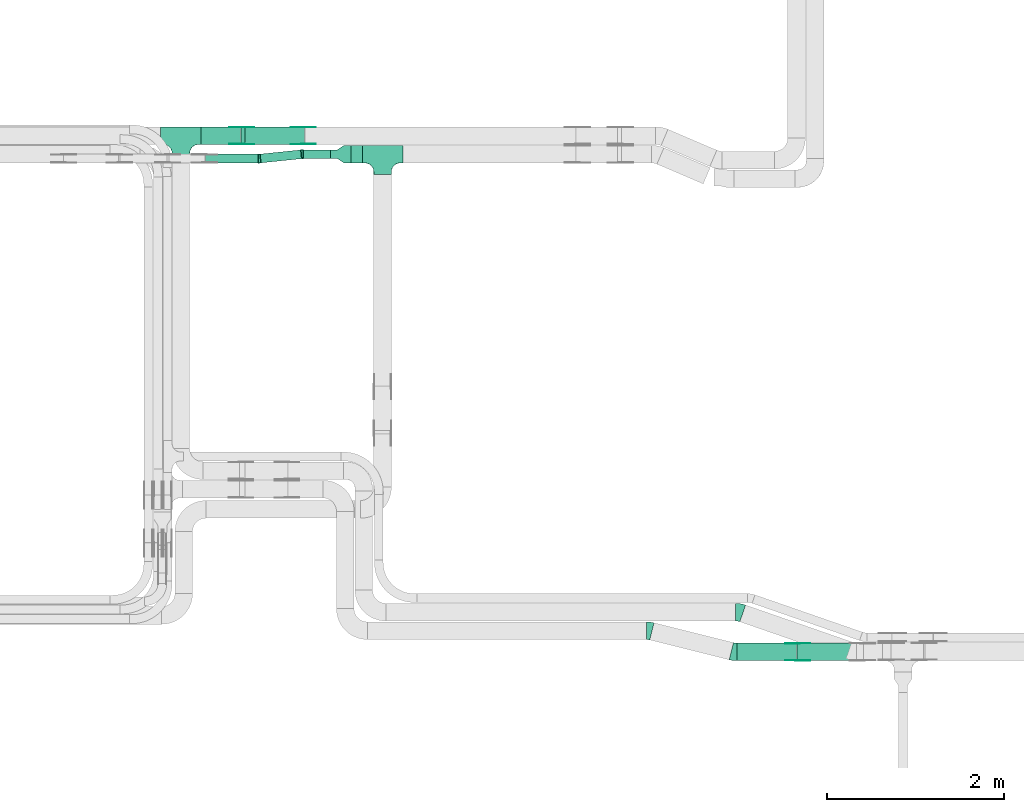
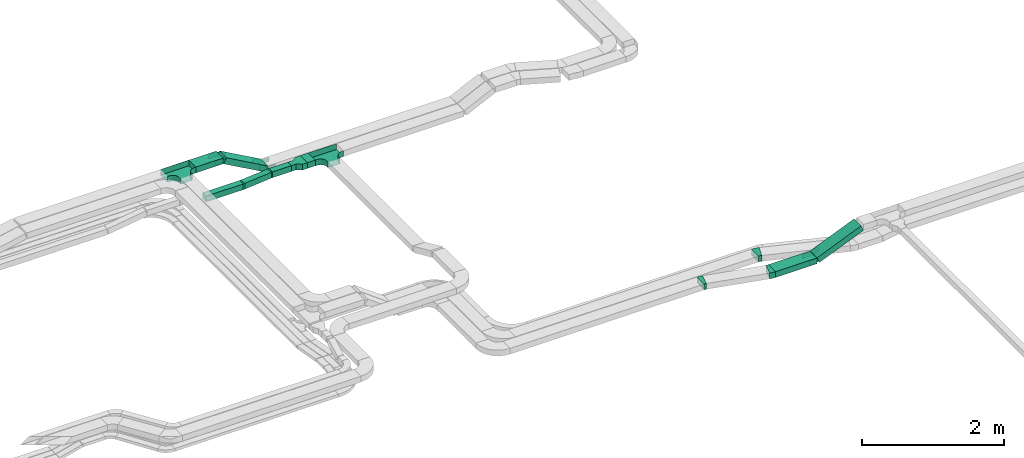
# One storey, part 13 of 25: 20 flow fittings, 8 flow segments.
"""IFC2X3 building model written with IfcOpenShell, lengths in millimetres."""

from ifc_helpers import new_model, entity, si_unit, converted_unit, derived_unit, direction, frame, frame_2d, origin, origin_2d_with_axis, place, context, subcontext, project, spatial, polyline, circle_curve, parameter, trimmed, segment, composite_curve, rectangle, outline, extrude, faceted_brep, source, transform, mapped, material, type_object, type_shapes, element, save


model = new_model("IFC2X3")

# Units and contexts
model_context = context("Model", 3, precision=0.01, world=origin(), true_north=direction((6.12303176911189e-17, 1.0)))
body_context = subcontext(model_context, "Body", "Model", "MODEL_VIEW")
ifc_project = project(units=[si_unit("LENGTHUNIT", "METRE", prefix="MILLI"), si_unit("AREAUNIT", "SQUARE_METRE"), si_unit("VOLUMEUNIT", "CUBIC_METRE"), converted_unit("PLANEANGLEUNIT", "DEGREE", entity("IfcRatioMeasure", 0.0174532925199433), si_unit("PLANEANGLEUNIT", "RADIAN"), dimensions=[0, 0, 0, 0, 0, 0, 0]), si_unit("MASSUNIT", "GRAM", prefix="KILO"), derived_unit("MASSDENSITYUNIT", [(si_unit("MASSUNIT", "GRAM", prefix="KILO"), 1), (si_unit("LENGTHUNIT", "METRE"), -3)]), derived_unit("MOMENTOFINERTIAUNIT", [(si_unit("LENGTHUNIT", "METRE"), 4)]), si_unit("TIMEUNIT", "SECOND"), si_unit("FREQUENCYUNIT", "HERTZ"), si_unit("THERMODYNAMICTEMPERATUREUNIT", "DEGREE_CELSIUS"), derived_unit("THERMALTRANSMITTANCEUNIT", [(si_unit("MASSUNIT", "GRAM", prefix="KILO"), 1), (si_unit("THERMODYNAMICTEMPERATUREUNIT", "KELVIN"), -1), (si_unit("TIMEUNIT", "SECOND"), -3)]), derived_unit("VOLUMETRICFLOWRATEUNIT", [(si_unit("LENGTHUNIT", "METRE"), 3), (si_unit("TIMEUNIT", "SECOND"), -1)]), derived_unit("MASSFLOWRATEUNIT", [(si_unit("MASSUNIT", "GRAM", prefix="KILO"), 1), (si_unit("TIMEUNIT", "SECOND"), -1)]), derived_unit("ROTATIONALFREQUENCYUNIT", [(si_unit("TIMEUNIT", "SECOND"), -1)]), si_unit("ELECTRICCURRENTUNIT", "AMPERE"), si_unit("ELECTRICVOLTAGEUNIT", "VOLT"), si_unit("POWERUNIT", "WATT"), si_unit("FORCEUNIT", "NEWTON", prefix="KILO"), si_unit("ILLUMINANCEUNIT", "LUX"), si_unit("LUMINOUSFLUXUNIT", "LUMEN"), si_unit("LUMINOUSINTENSITYUNIT", "CANDELA"), derived_unit("USERDEFINED", [(si_unit("MASSUNIT", "GRAM", prefix="KILO"), -1), (si_unit("LENGTHUNIT", "METRE"), -2), (si_unit("TIMEUNIT", "SECOND"), 3), (si_unit("LUMINOUSFLUXUNIT", "LUMEN"), 1)]), derived_unit("LINEARVELOCITYUNIT", [(si_unit("LENGTHUNIT", "METRE"), 1), (si_unit("TIMEUNIT", "SECOND"), -1)]), si_unit("PRESSUREUNIT", "PASCAL"), derived_unit("USERDEFINED", [(si_unit("LENGTHUNIT", "METRE"), -2), (si_unit("MASSUNIT", "GRAM", prefix="KILO"), 1), (si_unit("TIMEUNIT", "SECOND"), -2)]), derived_unit("LINEARFORCEUNIT", [(si_unit("MASSUNIT", "GRAM", prefix="KILO"), 1), (si_unit("LENGTHUNIT", "METRE"), 1), (si_unit("TIMEUNIT", "SECOND"), -2), (si_unit("LENGTHUNIT", "METRE"), -1)]), derived_unit("PLANARFORCEUNIT", [(si_unit("MASSUNIT", "GRAM", prefix="KILO"), 1), (si_unit("LENGTHUNIT", "METRE"), 1), (si_unit("TIMEUNIT", "SECOND"), -2), (si_unit("LENGTHUNIT", "METRE"), -2)])], contexts=[model_context])

# Site, building, storey
site_placement = place(None, frame((0.0, -0.00077364408347762, 0.0)))
site = spatial("IfcSite", under=ifc_project, at=site_placement, CompositionType="ELEMENT")
building_placement = place(site_placement, origin())
building = spatial("IfcBuilding", under=site, at=building_placement, CompositionType="ELEMENT")
storey_placement = place(building_placement, frame((0.0, 0.0, 24000.0)))
storey = spatial("IfcBuildingStorey", under=building, at=storey_placement, CompositionType="ELEMENT", Elevation=24000.0)

# Flow segments
cable_carrier_segment_type = type_object("IfcCableCarrierSegmentType", PredefinedType="CABLETRAYSEGMENT")
flow_segment_1_placement = place(storey_placement, frame((35176.2408475987, 14367.8235638229, 2650.0)))
element("IfcFlowSegment", 1, at=flow_segment_1_placement, inside=storey, type_object=cable_carrier_segment_type, context=body_context, shape_type="SweptSolid", body=[
    extrude(rectangle(XDim=129.37484695584, YDim=199.999999999998, at=frame_2d((-2.16715534406831e-12, 0.0), x_axis=(1.0, 0.0))), frame((64.6874234779181, 100.0, 0.0)), (0.0, 0.0, 1.0), 100.000000000003),
])
flow_segment_2_placement = place(storey_placement, frame((34637.5389879503, 14417.8235638229, 2650.0)))
element("IfcFlowSegment", 2, at=flow_segment_2_placement, inside=storey, type_object=cable_carrier_segment_type, context=body_context, shape_type="SweptSolid", body=[
    extrude(rectangle(XDim=308.701859648406, YDim=99.9999999999989, at=frame_2d((2.17426077142591e-12, 1.08357767203415e-12), x_axis=(1.0, 0.0))), frame((154.350929824205, 50.0, 0.0), z_axis=(0.0, 0.0, 1.0), x_axis=(-1.0, 0.0, 0.0)), (0.0, 0.0, 1.0), 100.000000000003),
])
flow_segment_3_placement = place(storey_placement, frame((33483.0827924389, 14577.8235638228, 3040.0)))
element("IfcFlowSegment", 3, at=flow_segment_3_placement, inside=storey, type_object=cable_carrier_segment_type, context=body_context, shape_type="SweptSolid", body=[
    extrude(rectangle(XDim=444.928950367665, YDim=200.000000000002, at=frame_2d((2.1600499167107e-12, 0.0), x_axis=(1.0, 0.0))), frame((222.464475183835, 100.0, 0.0)), (0.0, 0.0, 1.0), 99.9999999999989),
])
flow_segment_4_placement = place(storey_placement, frame((39544.8308070713, 8734.98923132572, 2660.0)))
element("IfcFlowSegment", 4, at=flow_segment_4_placement, inside=storey, type_object=cable_carrier_segment_type, context=body_context, shape_type="SweptSolid", body=[
    extrude(rectangle(XDim=676.342218198149, YDim=200.0, at=frame_2d((0.0, 1.08713038571295e-12), x_axis=(1.0, 0.0))), frame((338.171109099075, 100.0, 0.0)), (0.0, 0.0, 1.0), 100.000000000008),
])
flow_segment_5_placement = place(storey_placement, frame((40224.6474698943, 8734.98923132592, 2668.54525411596)))
element("IfcFlowSegment", 5, at=flow_segment_5_placement, inside=storey, type_object=cable_carrier_segment_type, context=body_context, shape_type="SweptSolid", body=[
    extrude(rectangle(XDim=99.9999999999999, YDim=200.0, at=frame_2d((-1.99662508748588e-12, 0.0), x_axis=(1.0, 0.0))), frame((19.4109706363734, 100.0, 46.0783487003825), z_axis=(0.921566974007608, 0.0, 0.388219412727468), x_axis=(-0.388219412727468, 0.0, 0.921566974007608)), (0.0, 0.0, 1.0), 774.697978791067),
])
flow_segment_6_placement = place(storey_placement, frame((33528.9358688632, 14367.8235638228, 2650.0)))
element("IfcFlowSegment", 6, at=flow_segment_6_placement, inside=storey, type_object=cable_carrier_segment_type, context=body_context, shape_type="SweptSolid", body=[
    extrude(rectangle(XDim=601.769552047414, YDim=99.9999999999989, at=frame_2d((2.1600499167107e-12, 1.08357767203415e-12), x_axis=(1.0, 0.0))), frame((300.884776023709, 50.0, 0.0)), (0.0, 0.0, 1.0), 100.000000000003),
])
flow_segment_7_placement = place(storey_placement, frame((34148.1064961002, 14369.2484137164, 2650.0)))
element("IfcFlowSegment", 7, at=flow_segment_7_placement, inside=storey, type_object=cable_carrier_segment_type, context=body_context, shape_type="SweptSolid", body=[
    extrude(rectangle(XDim=464.215540721123, YDim=100.000000000002, at=frame_2d((2.24531504500192e-12, 8.56203996590921e-13), x_axis=(1.0, 0.0))), frame((236.015708330252, 73.575150106427, 0.0), z_axis=(0.0, 0.0, 1.0), x_axis=(-0.994711436792197, -0.102709091685221, 0.0)), (0.0, 0.0, 1.0), 100.000000000003),
])
flow_segment_8_placement = place(storey_placement, frame((33931.8366351368, 14577.8235638228, 2663.71309977184)))
element("IfcFlowSegment", 8, at=flow_segment_8_placement, inside=storey, type_object=cable_carrier_segment_type, context=body_context, shape_type="SweptSolid", body=[
    extrude(rectangle(XDim=100.000000000003, YDim=200.000000000002, at=origin_2d_with_axis()), frame((24.4007076870417, 100.0, 418.932014695874), z_axis=(0.872835715211419, 0.0, -0.488014153740823), x_axis=(0.488014153740823, 0.0, 0.872835715211419)), (0.0, 0.0, 1.0), 769.01505019583),
])

# Flow fittings
ifc_material_1 = material(Name="G")
cable_carrier_fitting_type_1 = type_object("IfcCableCarrierFittingType", PredefinedType="NOTDEFINED", material=ifc_material_1)
shared_shape_1 = source(origin(), body_context, "Body", "SweptSolid", [
    extrude(outline(composite_curve([segment(trimmed(circle_curve(frame_2d((-41.4651162790697, 0.0), x_axis=(1.0, 0.0)), 25.0), [parameter(90.0000000000007)], [parameter(270.0)], True, "PARAMETER"), True, "CONTINUOUS"), segment(polyline([(-41.4651162790697, -25.0), (-29.9651162790697, -25.0)]), True, "CONTINUOUS"), segment(polyline([(-29.9651162790697, -25.0), (-28.1046511627907, -38.5)]), True, "CONTINUOUS"), segment(polyline([(-28.1046511627907, -38.5), (99.5348837209303, -38.5)]), True, "CONTINUOUS"), segment(polyline([(99.5348837209303, -38.5), (99.5348837209303, 38.5)]), True, "CONTINUOUS"), segment(polyline([(99.5348837209303, 38.5), (-28.1046511627907, 38.5)]), True, "CONTINUOUS"), segment(polyline([(-28.1046511627907, 38.5), (-29.9651162790697, 25.0)]), True, "CONTINUOUS"), segment(polyline([(-29.9651162790697, 25.0), (-41.46511627907, 25.0)]), True, "CONTINUOUS")], self_intersect=False)), frame((41.4651162790697, 0.0, 0.0), z_axis=(0.0, 0.0, -1.0), x_axis=(1.0, 0.0, 0.0)), (0.0, 0.0, -1.0), 2.0),
])
type_shapes(cable_carrier_fitting_type_1, [shared_shape_1])
for number, where, z_axis, x_axis in (
    (9, (40233.082792439, 8739.52923131576, 2710.0), (0.0, -1.0, 0.0), (0.921566974007647, 0.0, 0.388219412727376)),
    (10, (34640.6156945546, 14773.283563833, 2700.0), (0.0, 1.0, 0.0), (-0.872835715211393, 0.0, 0.488014153740868)),
    (11, (33943.0827924389, 14773.283563833, 3090.0), (0.0, 1.0, 0.0), (0.872835715211393, 0.0, -0.488014153740868)),
):
    element("IfcFlowFitting", number, at=place(storey_placement, frame(where, z_axis=z_axis, x_axis=x_axis)), inside=storey, type_object=cable_carrier_fitting_type_1, material=ifc_material_1, context=body_context, shape_type="MappedRepresentation", body=[
        mapped(shared_shape_1, transform((0.0, 0.0, 0.0), scale=1.0)),
    ])
cable_carrier_fitting_type_2 = type_object("IfcCableCarrierFittingType", PredefinedType="NOTDEFINED", material=ifc_material_1)
shared_shape_2 = source(origin(), body_context, "Body", "SweptSolid", [
    extrude(outline(composite_curve([segment(trimmed(circle_curve(frame_2d((-41.4651162790697, 0.0), x_axis=(1.0, 0.0)), 25.0), [parameter(90.0000000000007)], [parameter(270.0)], True, "PARAMETER"), True, "CONTINUOUS"), segment(polyline([(-41.4651162790697, -25.0), (-29.9651162790697, -25.0)]), True, "CONTINUOUS"), segment(polyline([(-29.9651162790697, -25.0), (-28.1046511627907, -38.5)]), True, "CONTINUOUS"), segment(polyline([(-28.1046511627907, -38.5), (99.5348837209303, -38.5)]), True, "CONTINUOUS"), segment(polyline([(99.5348837209303, -38.5), (99.5348837209303, 38.5)]), True, "CONTINUOUS"), segment(polyline([(99.5348837209303, 38.5), (-28.1046511627907, 38.5)]), True, "CONTINUOUS"), segment(polyline([(-28.1046511627907, 38.5), (-29.9651162790697, 25.0)]), True, "CONTINUOUS"), segment(polyline([(-29.9651162790697, 25.0), (-41.46511627907, 25.0)]), True, "CONTINUOUS")], self_intersect=False)), frame((41.4651162790697, 0.0, 0.0)), (0.0, 0.0, 1.0), 2.0),
])
type_shapes(cable_carrier_fitting_type_2, [shared_shape_2])
for number, where, z_axis, x_axis in (
    (12, (40233.082792439, 8930.44923133608, 2710.0), (0.0, 1.0, 0.0), (0.921566974007647, 0.0, 0.388219412727376)),
    (13, (34640.6156945547, 14582.3635638127, 2700.0), (0.0, -1.0, 0.0), (-0.872835715211393, 0.0, 0.488014153740868)),
    (14, (33943.0827924389, 14582.3635638127, 3090.0), (0.0, -1.0, 0.0), (0.872835715211393, 0.0, -0.488014153740868)),
):
    element("IfcFlowFitting", number, at=place(storey_placement, frame(where, z_axis=z_axis, x_axis=x_axis)), inside=storey, type_object=cable_carrier_fitting_type_2, material=ifc_material_1, context=body_context, shape_type="MappedRepresentation", body=[
        mapped(shared_shape_2, transform((0.0, 0.0, 0.0), scale=1.0)),
    ])
cable_carrier_fitting_type_3 = type_object("IfcCableCarrierFittingType", PredefinedType="NOTDEFINED", material=ifc_material_1)
shared_shape_3 = source(origin(), body_context, "Body", "SweptSolid", [
    extrude(outline(composite_curve([segment(trimmed(circle_curve(frame_2d((-41.4651162790697, 0.0), x_axis=(1.0, 0.0)), 25.0), [parameter(90.0000000000007)], [parameter(270.0)], True, "PARAMETER"), True, "CONTINUOUS"), segment(polyline([(-41.4651162790697, -25.0), (-29.9651162790697, -25.0)]), True, "CONTINUOUS"), segment(polyline([(-29.9651162790697, -25.0), (-28.1046511627907, -38.5)]), True, "CONTINUOUS"), segment(polyline([(-28.1046511627907, -38.5), (99.5348837209303, -38.5)]), True, "CONTINUOUS"), segment(polyline([(99.5348837209303, -38.5), (99.5348837209303, 38.5)]), True, "CONTINUOUS"), segment(polyline([(99.5348837209303, 38.5), (-28.1046511627907, 38.5)]), True, "CONTINUOUS"), segment(polyline([(-28.1046511627907, 38.5), (-29.9651162790697, 25.0)]), True, "CONTINUOUS"), segment(polyline([(-29.9651162790697, 25.0), (-41.46511627907, 25.0)]), True, "CONTINUOUS")], self_intersect=False)), frame((41.4651162790697, 0.0, 0.0), z_axis=(0.0, 0.0, -1.0), x_axis=(1.0, 0.0, 0.0)), (0.0, 0.0, -1.0), 2.0),
])
type_shapes(cable_carrier_fitting_type_3, [shared_shape_3])
for number, where, z_axis, x_axis in (
    (15, (40233.082792439, 8928.44923133608, 2710.0), (0.0, 1.0, 0.0), (-1.0, 0.0, 0.0)),
    (16, (34640.6156945546, 14584.3635638127, 2700.0), (0.0, -1.0, 0.0), (1.0, 0.0, 0.0)),
    (17, (33943.0827924389, 14584.3635638127, 3090.0), (0.0, -1.0, 0.0), (-1.0, 0.0, 0.0)),
):
    element("IfcFlowFitting", number, at=place(storey_placement, frame(where, z_axis=z_axis, x_axis=x_axis)), inside=storey, type_object=cable_carrier_fitting_type_3, material=ifc_material_1, context=body_context, shape_type="MappedRepresentation", body=[
        mapped(shared_shape_3, transform((0.0, 0.0, 0.0), scale=1.0)),
    ])
cable_carrier_fitting_type_4 = type_object("IfcCableCarrierFittingType", PredefinedType="NOTDEFINED", material=ifc_material_1)
shared_shape_4 = source(origin(), body_context, "Body", "SweptSolid", [
    extrude(outline(composite_curve([segment(trimmed(circle_curve(frame_2d((-41.4651162790697, 0.0), x_axis=(1.0, 0.0)), 25.0), [parameter(90.0000000000007)], [parameter(270.0)], True, "PARAMETER"), True, "CONTINUOUS"), segment(polyline([(-41.4651162790697, -25.0), (-29.9651162790697, -25.0)]), True, "CONTINUOUS"), segment(polyline([(-29.9651162790697, -25.0), (-28.1046511627907, -38.5)]), True, "CONTINUOUS"), segment(polyline([(-28.1046511627907, -38.5), (99.5348837209303, -38.5)]), True, "CONTINUOUS"), segment(polyline([(99.5348837209303, -38.5), (99.5348837209303, 38.5)]), True, "CONTINUOUS"), segment(polyline([(99.5348837209303, 38.5), (-28.1046511627907, 38.5)]), True, "CONTINUOUS"), segment(polyline([(-28.1046511627907, 38.5), (-29.9651162790697, 25.0)]), True, "CONTINUOUS"), segment(polyline([(-29.9651162790697, 25.0), (-41.46511627907, 25.0)]), True, "CONTINUOUS")], self_intersect=False)), frame((41.4651162790697, 0.0, 0.0)), (0.0, 0.0, 1.0), 2.0),
])
type_shapes(cable_carrier_fitting_type_4, [shared_shape_4])
for number, where, z_axis, x_axis in (
    (18, (40233.082792439, 8741.52923131576, 2710.0), (0.0, -1.0, 0.0), (-1.0, 0.0, 0.0)),
    (19, (34640.6156945546, 14771.283563833, 2700.0), (0.0, 1.0, 0.0), (1.0, 0.0, 0.0)),
    (20, (33943.0827924389, 14771.283563833, 3090.0), (0.0, 1.0, 0.0), (-1.0, 0.0, 0.0)),
):
    element("IfcFlowFitting", number, at=place(storey_placement, frame(where, z_axis=z_axis, x_axis=x_axis)), inside=storey, type_object=cable_carrier_fitting_type_4, material=ifc_material_1, context=body_context, shape_type="MappedRepresentation", body=[
        mapped(shared_shape_4, transform((0.0, 0.0, 0.0), scale=1.0)),
    ])
ifc_material_2 = material()
cable_carrier_fitting_type_5 = type_object("IfcCableCarrierFittingType", PredefinedType="NOTDEFINED", material=ifc_material_2)
shared_shape_5 = source(origin(), body_context, "Body", "SweptSolid", [
    extrude(outline(polyline([(-115.0, 50.0), (-115.0, -50.0), (-38.3333333333284, -50.0), (38.3333333333382, -100.0), (115.0, -100.0), (115.0, 100.0), (38.3333333333252, 100.0), (-38.3333333333284, 50.0), (-115.0, 50.0)])), frame((115.0, 0.0, -50.0), z_axis=(0.0, 0.0, -1.0), x_axis=(1.0, 0.0, 0.0)), (0.0, 0.0, -1.0), 100.0),
])
type_shapes(cable_carrier_fitting_type_5, [shared_shape_5])
flow_fitting_1_placement = place(storey_placement, frame((34946.2408475987, 14467.8235638229, 2700.0)))
element("IfcFlowFitting", 21, at=flow_fitting_1_placement, inside=storey, type_object=cable_carrier_fitting_type_5, material=ifc_material_2, Name="470_DKC_S5_adapter", context=body_context, shape_type="MappedRepresentation", body=[
    mapped(shared_shape_5, transform((0.0, 0.0, 0.0), scale=1.0)),
])
cable_carrier_fitting_type_6 = type_object("IfcCableCarrierFittingType", PredefinedType="NOTDEFINED", material=ifc_material_2)
shared_shape_6 = source(origin(), body_context, "Body", "Brep", [
    faceted_brep([(-103.407417371087, -174.118095489753, 50.0), (-100.0, -200.0, 50.0), (-100.0, -230.0, 50.0), (-99.1999999999932, -230.0, 50.0), (-99.1999999999933, -200.0, 50.0), (-102.634676710055, -173.911040253671, 50.0), (-112.704639298522, -149.600000000004, 50.0), (-128.723636456391, -128.7236364564, 50.0), (-149.599999999996, -112.704639298532, 50.0), (-173.911040253663, -102.634676710066, 50.0), (-200.0, -99.2000000000044, 50.0), (-230.0, -99.2000000000044, 50.0), (-230.0, -100.0, 50.0), (-200.0, -100.0, 50.0), (-174.118095489746, -103.407417371099, 50.0), (-150.0, -113.397459621561, 50.0), (-129.28932188134, -129.28932188135, 50.0), (-113.39745962155, -150.0, 50.0), (230.0, -100.0, 50.0), (230.0, -99.2000000000044, 50.0), (200.0, -99.2000000000097, 50.0), (173.911040253722, -102.634676710071, 50.0), (149.60000000005, -112.704639298537, 50.0), (128.723636456439, -128.723636456403, 50.0), (112.704639298563, -149.600000000006, 50.0), (102.634676710086, -173.911040253673, 50.0), (99.2000000000121, -200.0, 50.0), (99.2000000000069, -230.0, 50.0), (100.0, -230.0, 50.0), (100.0, -200.0, 50.0), (103.407417371119, -174.118095489755, 50.0), (113.397459621593, -150.0, 50.0), (129.289321881391, -129.289321881354, 50.0), (150.0, -113.397459621567, 50.0), (174.118095489805, -103.407417371105, 50.0), (200.0, -100.0, 50.0), (230.0, 99.1999999999954, 50.0), (230.0, 100.0, 50.0), (-230.0, 100.0, 50.0), (-230.0, 99.1999999999954, 50.0), (-230.0, -100.0, -50.0), (-230.0, 100.0, -50.0), (230.0, 100.0, -50.0), (230.0, -100.0, -50.0), (200.0, -100.0, -50.0), (174.118095489805, -103.407417371105, -50.0), (150.0, -113.397459621567, -50.0), (129.289321881391, -129.289321881354, -50.0), (113.397459621593, -150.0, -50.0), (103.407417371119, -174.118095489755, -50.0), (100.0, -200.0, -50.0), (100.0, -230.0, -50.0), (-100.0, -230.0, -50.0), (-100.0, -200.0, -50.0), (-103.407417371087, -174.118095489753, -50.0), (-113.39745962155, -150.0, -50.0), (-129.28932188134, -129.28932188135, -50.0), (-150.0, -113.397459621561, -50.0), (-174.118095489746, -103.407417371099, -50.0), (-200.0, -100.0, -50.0), (-100.0, -200.0, -49.1999999999851), (99.2000000000069, -230.0, -49.1999999999851), (-99.1999999999932, -230.0, -49.1999999999851), (-99.1999999999933, -200.0, -49.1999999999851), (-200.0, -99.2000000000044, -49.1999999999851), (-230.0, -99.2000000000044, -49.1999999999851), (230.0, -99.2000000000044, -49.1999999999851), (200.0, -99.2000000000044, -49.1999999999851), (-230.0, 99.1999999999954, -49.1999999999851), (-200.0, -100.0, -49.1999999999851), (200.0, -100.0, -49.1999999999851), (230.0, 99.1999999999954, -49.1999999999851), (99.2000000000121, -200.0, -49.1999999999851), (100.0, -200.0, -49.1999999999851), (-173.911040253663, -102.634676710066, -49.1999999999851), (-149.599999999996, -112.704639298532, -49.1999999999851), (-128.723636456391, -128.7236364564, -49.1999999999851), (-112.704639298522, -149.600000000004, -49.1999999999851), (-102.634676710055, -173.911040253671, -49.1999999999851), (102.634676710086, -173.911040253674, -49.1999999999851), (112.704639298563, -149.600000000007, -49.1999999999851), (128.723636456439, -128.723636456403, -49.1999999999851), (149.60000000005, -112.704639298537, -49.1999999999851), (173.911040253721, -102.634676710071, -49.1999999999851)], [[[0, 1, 2, 3, 4, 5, 6, 7, 8, 9, 10, 11, 12, 13, 14, 15, 16, 17]], [[18, 19, 20, 21, 22, 23, 24, 25, 26, 27, 28, 29, 30, 31, 32, 33, 34, 35]], [[36, 37, 38, 39]], [[40, 41, 42, 43, 44, 45, 46, 47, 48, 49, 50, 51, 52, 53, 54, 55, 56, 57, 58, 59]], [[2, 1, 60, 53, 52]], [[3, 2, 52, 51, 28, 27, 61, 62]], [[4, 3, 62, 63]], [[11, 10, 64, 65]], [[20, 19, 66, 67]], [[39, 38, 41, 40, 12, 11, 65, 68]], [[13, 12, 40, 59, 69]], [[18, 35, 70, 44, 43]], [[19, 18, 43, 42, 37, 36, 71, 66]], [[27, 26, 72, 61]], [[29, 28, 51, 50, 73]], [[38, 37, 42, 41]], [[36, 39, 68, 71]], [[68, 65, 64, 74, 75, 76, 77, 78, 63, 62, 61, 72, 79, 80, 81, 82, 83, 67, 66, 71]], [[14, 13, 69, 59, 58]], [[15, 14, 58, 57]], [[57, 56, 16, 15]], [[17, 16, 56, 55]], [[0, 17, 55, 54]], [[1, 0, 54, 53, 60]], [[5, 78, 77, 6]], [[6, 77, 76, 7]], [[63, 78, 5, 4]], [[8, 75, 74, 9]], [[9, 74, 64, 10]], [[7, 76, 75, 8]], [[21, 83, 82, 22]], [[22, 82, 81, 23]], [[67, 83, 21, 20]], [[24, 80, 79, 25]], [[25, 79, 72, 26]], [[23, 81, 80, 24]], [[30, 29, 73, 50, 49]], [[31, 30, 49, 48]], [[32, 31, 48, 47]], [[34, 33, 46, 45]], [[34, 45, 44, 70, 35]], [[46, 33, 32, 47]]]),
])
type_shapes(cable_carrier_fitting_type_6, [shared_shape_6])
for number, where, name in (
    (22, (35535.6156945545, 14467.8235638229, 2700.0), "470_DKC_S5_T"),
    (23, (33253.0827924389, 14677.8235638228, 3090.0), "470_DKC_S5_T"),
):
    element("IfcFlowFitting", number, at=place(storey_placement, frame(where)), inside=storey, type_object=cable_carrier_fitting_type_6, material=ifc_material_2, Name=name, context=body_context, shape_type="MappedRepresentation", body=[
        mapped(shared_shape_6, transform((0.0, 0.0, 0.0), scale=1.0)),
    ])
cable_carrier_fitting_type_7 = type_object("IfcCableCarrierFittingType", Name="470_DKC_S5_Variable Angle Elbow 0-45:-", PredefinedType="NOTDEFINED", material=ifc_material_2)
shared_shape_7 = source(origin(), body_context, "Body", "SweptSolid", [
    extrude(outline(composite_curve([segment(polyline([(-11.2695870277168, -50.5545335937012), (-10.2695870277155, -50.5545335937012)]), True, "CONTINUOUS"), segment(trimmed(circle_curve(frame_2d((-10.2695870277181, 199.445466406298), x_axis=(0.0, -1.0)), 250.0), [parameter(0.0)], [parameter(5.89519350767973)], True, "PARAMETER"), True, "CONTINUOUS"), segment(polyline([(15.4076858935798, -49.2323927917512), (16.4023973303718, -49.1296837000661)]), True, "CONTINUOUS"), segment(polyline([(16.4023973303718, -49.1296837000661), (6.13148816185302, 50.3414599791538)]), True, "CONTINUOUS"), segment(polyline([(6.13148816185302, 50.3414599791538), (5.13677672506061, 50.2387508874687)]), True, "CONTINUOUS"), segment(trimmed(circle_curve(frame_2d((-10.2695870277181, 199.445466406298), x_axis=(0.0, -1.0)), 150.0), [parameter(0.0)], [parameter(5.89519350767973)], True, "PARAMETER"), False, "CONTINUOUS"), segment(polyline([(-10.2695870277163, 49.4454664062986), (-11.2695870277176, 49.4454664062986)]), True, "CONTINUOUS"), segment(polyline([(-11.2695870277176, 49.4454664062986), (-11.2695870277168, -50.5545335937012)]), True, "CONTINUOUS")], self_intersect=False)), frame((-0.0285533238782562, 0.554533593693097, -50.0)), (0.0, 0.0, 1.0), 100.0),
])
type_shapes(cable_carrier_fitting_type_7, [shared_shape_7])
flow_fitting_2_placement = place(storey_placement, frame((34626.2408475987, 14467.8235638229, 2700.0), z_axis=(0.0, 0.0, 1.0), x_axis=(-1.0, 0.0, 0.0)))
element("IfcFlowFitting", 24, at=flow_fitting_2_placement, inside=storey, type_object=cable_carrier_fitting_type_7, material=ifc_material_2, Name="470_DKC_S5_Variable Angle Elbow 0-45:-", ObjectType="470_DKC_S5_Variable Angle Elbow 0-45:-", context=body_context, shape_type="MappedRepresentation", body=[
    mapped(shared_shape_7, transform((0.0, 0.0, 0.0), scale=1.0)),
])
flow_fitting_3_placement = place(storey_placement, frame((34142.0035612623, 14417.8235638228, 2700.0)))
element("IfcFlowFitting", 25, at=flow_fitting_3_placement, inside=storey, type_object=cable_carrier_fitting_type_7, material=ifc_material_2, Name="470_DKC_S5_Variable Angle Elbow 0-45:-", ObjectType="470_DKC_S5_Variable Angle Elbow 0-45:-", context=body_context, shape_type="MappedRepresentation", body=[
    mapped(shared_shape_7, transform((0.0, 0.0, 0.0), scale=1.0)),
])
cable_carrier_fitting_type_8 = type_object("IfcCableCarrierFittingType", Name="470_DKC_S5_Variable Angle Elbow 0-45:-", PredefinedType="NOTDEFINED", material=ifc_material_2)
shared_shape_8 = source(origin(), body_context, "Body", "SweptSolid", [
    extrude(outline(composite_curve([segment(polyline([(-31.2823683167082, -103.785986845691), (-30.2823683167068, -103.785986845691)]), True, "CONTINUOUS"), segment(trimmed(circle_curve(frame_2d((-30.2823683167074, 246.214013154308), x_axis=(0.0, -1.0)), 350.0), [parameter(0.0)], [parameter(14.0234237419715)], True, "PARAMETER"), True, "CONTINUOUS"), segment(polyline([(54.5291252504347, -93.3548466648899), (55.499321992775, -93.112528111841)]), True, "CONTINUOUS"), segment(polyline([(55.499321992775, -93.112528111841), (7.03561138297993, 100.926820356273)]), True, "CONTINUOUS"), segment(polyline([(7.03561138297994, 100.926820356273), (6.06541464063916, 100.684501803224)]), True, "CONTINUOUS"), segment(trimmed(circle_curve(frame_2d((-30.2823683167074, 246.214013154308), x_axis=(0.0, -1.0)), 150.0), [parameter(0.0)], [parameter(14.0234237419715)], True, "PARAMETER"), False, "CONTINUOUS"), segment(polyline([(-30.2823683167068, 96.2140131543086), (-31.2823683167082, 96.2140131543086)]), True, "CONTINUOUS"), segment(polyline([(-31.2823683167082, 96.2140131543086), (-31.2823683167082, -103.785986845691)]), True, "CONTINUOUS")], self_intersect=False)), frame((-0.465646315708043, 3.78598684568319, -50.0)), (0.0, 0.0, 1.0), 100.0),
])
type_shapes(cable_carrier_fitting_type_8, [shared_shape_8])
for number, where, z_axis, x_axis, name in (
    (26, (39513.0827924388, 8834.98923132574, 2710.0), (0.0, 0.0, 1.0), (0.970196742340567, -0.242318553048981, 0.0), "470_DKC_S5_Variable Angle Elbow 0-45:-"),
    (27, (38552.3560473679, 9074.94253623933, 2710.0), (0.0, 0.0, 1.0), (-0.970196742340565, 0.242318553048987, 0.0), "470_DKC_S5_Variable Angle Elbow 0-45:-"),
):
    element("IfcFlowFitting", number, at=place(storey_placement, frame(where, z_axis=z_axis, x_axis=x_axis)), inside=storey, type_object=cable_carrier_fitting_type_8, material=ifc_material_2, Name=name, ObjectType="470_DKC_S5_Variable Angle Elbow 0-45:-", context=body_context, shape_type="MappedRepresentation", body=[
        mapped(shared_shape_8, transform((0.0, 0.0, 0.0), scale=1.0)),
    ])
cable_carrier_fitting_type_9 = type_object("IfcCableCarrierFittingType", Name="470_DKC_S5_Variable Angle Elbow 0-45:-", PredefinedType="NOTDEFINED", material=ifc_material_2)
shared_shape_9 = source(origin(), body_context, "Body", "SweptSolid", [
    extrude(outline(composite_curve([segment(polyline([(-41.9646328661209, -106.989760877664), (-40.9646328661195, -106.989760877664)]), True, "CONTINUOUS"), segment(trimmed(circle_curve(frame_2d((-40.9646328661201, 243.010239122336), x_axis=(0.0, -1.0)), 350.0), [parameter(0.0)], [parameter(19.136971841609)], True, "PARAMETER"), True, "CONTINUOUS"), segment(polyline([(73.775022861308, -87.6479097316597), (74.7197604294621, -87.3200821438672)]), True, "CONTINUOUS"), segment(polyline([(74.7197604294621, -87.3200821438672), (9.1542428709321, 101.627431486988)]), True, "CONTINUOUS"), segment(polyline([(9.1542428709321, 101.627431486988), (8.20950530277761, 101.299603899195)]), True, "CONTINUOUS"), segment(trimmed(circle_curve(frame_2d((-40.9646328661201, 243.010239122336), x_axis=(0.0, -1.0)), 150.0), [parameter(0.0)], [parameter(19.136971841609)], True, "PARAMETER"), False, "CONTINUOUS"), segment(polyline([(-40.9646328661195, 93.0102391223359), (-41.9646328661209, 93.0102391223359)]), True, "CONTINUOUS"), segment(polyline([(-41.9646328661209, 93.0102391223359), (-41.9646328661209, -106.989760877664)]), True, "CONTINUOUS")], self_intersect=False)), frame((-1.17827540603723, 6.98976087765586, -50.0)), (0.0, 0.0, 1.0), 100.0),
])
type_shapes(cable_carrier_fitting_type_9, [shared_shape_9])
flow_fitting_4_placement = place(storey_placement, frame((39570.8109504707, 9284.94253623978, 2710.0), z_axis=(0.0, 0.0, 1.0), x_axis=(-0.944737568154262, 0.327827587792687, 0.0)))
element("IfcFlowFitting", 28, at=flow_fitting_4_placement, inside=storey, type_object=cable_carrier_fitting_type_9, material=ifc_material_2, Name="470_DKC_S5_Variable Angle Elbow 0-45:-", ObjectType="470_DKC_S5_Variable Angle Elbow 0-45:-", context=body_context, shape_type="MappedRepresentation", body=[
    mapped(shared_shape_9, transform((0.0, 0.0, 0.0), scale=1.0)),
])

save(model, "model.ifc")
